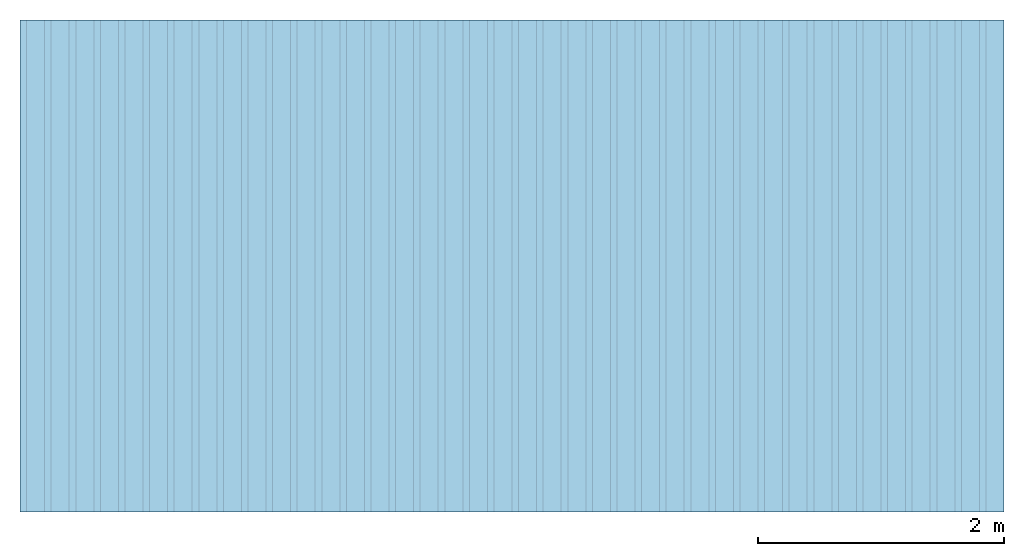
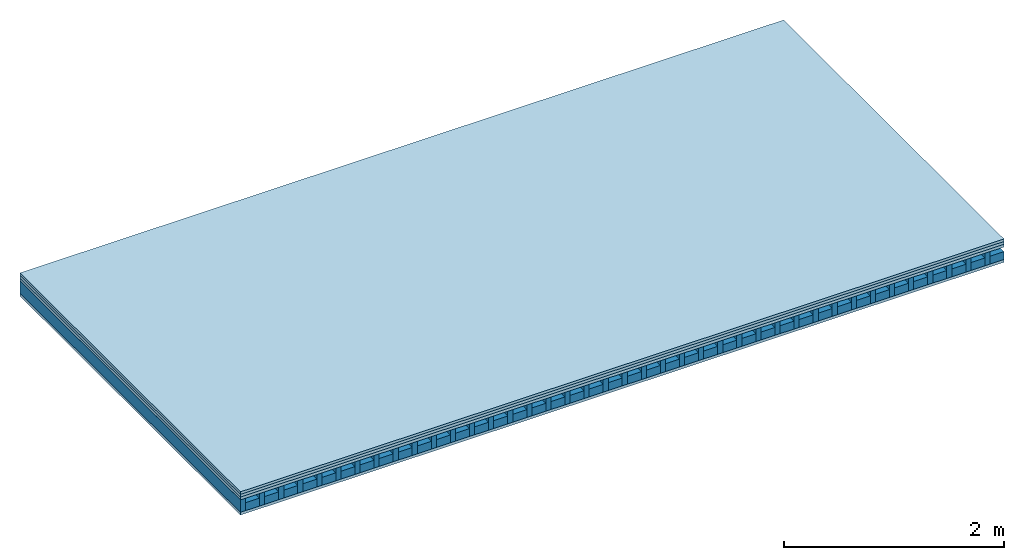
# One storey: 4 plates, 2 members, 1 element without a shape of its own.
"""IFC4 building model written with IfcOpenShell, lengths in metres."""

import ifcopenshell
import ifcopenshell.guid

model = None  # the IFC model being written
_history = None  # IfcOwnerHistory: only IFC2X3 demands one
_inside = {}  # id of a spatial element -> (the spatial element, [elements in it])
_under = {}  # id of a project, library or spatial element -> (it, [spatial elements below it])
_declared = {}  # id of a project -> (the project, [libraries it declares])
_typed = {}  # id of a type object -> (the type object, [elements of that type])
_made_of = {}  # id of a material, layer set ... -> (it, [elements and type objects made of it])


def new_model(schema):
    """Start an empty IFC model of exactly this schema.

    Asked for "IFC4X3", IfcOpenShell would pick the latest addendum, in which some entities
    have other attributes; the version numbers below select the first issue.
    IFC2X3 requires an IfcOwnerHistory on every rooted entity: one is made here for all.
    """
    global model, _history
    if schema == "IFC4X3":
        model = ifcopenshell.file(schema_version=(4, 3, 0, 0))
    else:
        model = ifcopenshell.file(schema=schema)
    _inside.clear()
    _under.clear()
    _declared.clear()
    _typed.clear()
    _made_of.clear()
    _history = None
    if model.schema == "IFC2X3":
        org = make("IfcOrganization", Name="unknown")
        user = make(
            "IfcPersonAndOrganization",
            ThePerson=make("IfcPerson", FamilyName="unknown"),
            TheOrganization=org,
        )
        app = make(
            "IfcApplication",
            ApplicationDeveloper=org,
            Version="unknown",
            ApplicationFullName="unknown",
            ApplicationIdentifier="unknown",
        )
        _history = make(
            "IfcOwnerHistory",
            OwningUser=user,
            OwningApplication=app,
            ChangeAction="ADDED",
            CreationDate=0,
        )
    return model


def make(cls, **values):
    """One entity of the class cls with the attributes given. An attribute that is None is left unset."""
    return model.create_entity(
        cls, **{name: value for name, value in values.items() if value is not None}
    )


def rooted(cls, **values):
    """An entity with a GlobalId (a new one), such as an element, a storey or a relation."""
    return make(cls, GlobalId=ifcopenshell.guid.new(), OwnerHistory=_history, **values)


def si_unit(unit_type, name, prefix=None):
    """IfcSIUnit, for example si_unit("LENGTHUNIT", "METRE", prefix="MILLI")."""
    return make("IfcSIUnit", UnitType=unit_type, Prefix=prefix, Name=name)


def derived_unit(unit_type, elements):
    """IfcDerivedUnit: a product of units, each with its exponent."""
    return make(
        "IfcDerivedUnit",
        Elements=[
            make("IfcDerivedUnitElement", Unit=unit, Exponent=power)
            for unit, power in elements
        ],
        UnitType=unit_type,
    )


def assignment(units):
    """IfcUnitAssignment: the units of a project."""
    return None if units is None else make("IfcUnitAssignment", Units=units)


def point(xyz):
    """IfcCartesianPoint."""
    return None if xyz is None else make("IfcCartesianPoint", Coordinates=xyz)


def direction(xyz):
    """IfcDirection."""
    return None if xyz is None else make("IfcDirection", DirectionRatios=xyz)


def frame(location, z_axis=None, x_axis=None):
    """IfcAxis2Placement3D, a coordinate frame: its origin and axes. An axis left out is left unset."""
    return make(
        "IfcAxis2Placement3D",
        Location=point(location),
        Axis=direction(z_axis),
        RefDirection=direction(x_axis),
    )


def frame_2d(location, x_axis=None):
    """IfcAxis2Placement2D, a coordinate frame in the plane: its origin and x axis."""
    return make(
        "IfcAxis2Placement2D", Location=point(location), RefDirection=direction(x_axis)
    )


def origin():
    """The frame at (0, 0, 0) with its axes left unset."""
    return frame((0.0, 0.0, 0.0))


def origin_with_axes():
    """The frame at (0, 0, 0) with the z axis (0, 0, 1) and the x axis (1, 0, 0) written out."""
    return frame((0.0, 0.0, 0.0), z_axis=(0.0, 0.0, 1.0), x_axis=(1.0, 0.0, 0.0))


def place(relative_to, where):
    """IfcLocalPlacement: puts the frame where relative to a parent placement (None: the world)."""
    return make(
        "IfcLocalPlacement", PlacementRelTo=relative_to, RelativePlacement=where
    )


def context(
    kind, dimensions, precision=None, world=None, true_north=None, identifier=None
):
    """IfcGeometricRepresentationContext, for example the 3D "Model" context."""
    return make(
        "IfcGeometricRepresentationContext",
        ContextIdentifier=identifier,
        ContextType=kind,
        CoordinateSpaceDimension=dimensions,
        Precision=precision,
        WorldCoordinateSystem=world,
        TrueNorth=true_north,
    )


def project(units=None, contexts=None):
    """IfcProject with its units and contexts."""
    return rooted(
        "IfcProject",
        Name="project",
        RepresentationContexts=contexts,
        UnitsInContext=assignment(units),
    )


def spatial(cls, under=None, at=None, **own):
    """A site, building, storey or space (cls), placed at a placement, below another one or the project."""
    s = rooted(cls, ObjectPlacement=at, **own)
    if under is not None:
        _under.setdefault(under.id(), (under, []))[1].append(s)
    return s


def profile(cls, at=None, kind="AREA", **sizes):
    """A parametric profile (cls). Its sizes go by their IFC names, for example OverallWidth=200.0."""
    return make(cls, ProfileType=kind, Position=at, **sizes)


def rectangle(**sizes):
    """IfcRectangleProfileDef."""
    return profile("IfcRectangleProfileDef", **sizes)


def extrude(swept, where, along, depth):
    """IfcExtrudedAreaSolid: the profile swept, set in the frame where, extruded along a direction by depth."""
    return make(
        "IfcExtrudedAreaSolid",
        SweptArea=swept,
        Position=where,
        ExtrudedDirection=direction(along),
        Depth=depth,
    )


def shape(context_of_items, identifier, shape_type, items):
    """IfcShapeRepresentation: the items that make up one representation, for example the "Body"."""
    return make(
        "IfcShapeRepresentation",
        ContextOfItems=context_of_items,
        RepresentationIdentifier=identifier,
        RepresentationType=shape_type,
        Items=items,
    )


def material(Name=None, Category=None):
    """IfcMaterial."""
    return make("IfcMaterial", Name=Name, Category=Category)


def layer(
    of_material, thickness, ventilated=None, Name=None, Category=None, Priority=None
):
    """IfcMaterialLayer: one layer of a wall or slab, of a material (None: an air gap)."""
    return make(
        "IfcMaterialLayer",
        Material=of_material,
        LayerThickness=thickness,
        IsVentilated=ventilated,
        Name=Name,
        Category=Category,
        Priority=Priority,
    )


def layer_set(layers, Name=None):
    """IfcMaterialLayerSet."""
    return make("IfcMaterialLayerSet", MaterialLayers=layers, LayerSetName=Name)


def made_of(thing, what):
    """Note that an element or type object is made of a material, layer set ...; save() writes the relation."""
    if what is not None:
        _made_of.setdefault(what.id(), (what, []))[1].append(thing)
    return thing


def type_object(cls, material=None, **own):
    """A type object (cls), such as IfcWallType, which elements share."""
    return made_of(rooted(cls, **own), material)


def element(
    cls,
    number,
    at=None,
    inside=None,
    cuts=None,
    type_object=None,
    material=None,
    context=None,
    identifier="Body",
    shape_type=None,
    held_by="IfcProductDefinitionShape",
    body=None,
    shapes=None,
    **own,
):
    """One element of the class cls, such as IfcWall. Its Tag is "e" and its number.

    at: its placement. inside: the storey or other place that contains it. cuts: it is an
    opening in that element (IfcRelVoidsElement). A single representation is given by context,
    identifier, shape_type and body (its items); several are given by shapes. held_by: the class
    of the entity that holds the representations. save() writes the other relations.
    """
    e = rooted(cls, Tag="e%d" % number, ObjectPlacement=at, **own)
    if body is not None:
        shapes = [shape(context, identifier, shape_type, body)]
    if shapes is not None:
        e.Representation = make(held_by, Representations=shapes)
    if inside is not None:
        _inside.setdefault(inside.id(), (inside, []))[1].append(e)
    if cuts is not None:
        rooted(
            "IfcRelVoidsElement", RelatingBuildingElement=cuts, RelatedOpeningElement=e
        )
    if type_object is not None:
        _typed.setdefault(type_object.id(), (type_object, []))[1].append(e)
    return made_of(e, material)


def aggregate(whole, parts):
    """IfcRelAggregates: a whole, such as a stair, and the parts it consists of."""
    return rooted("IfcRelAggregates", RelatingObject=whole, RelatedObjects=parts)


def save(model, path):
    """Write the relations noted so far, then the file.

    IfcRelAggregates (storeys below a building ...), IfcRelContainedInSpatialStructure (elements
    in a storey), IfcRelDefinesByType, IfcRelAssociatesMaterial and IfcRelDeclares: one each for
    every whole, place, type object, material and project.
    """
    for whole, parts in _under.values():
        aggregate(whole, parts)
    for where, things in _inside.values():
        rooted(
            "IfcRelContainedInSpatialStructure",
            RelatedElements=things,
            RelatingStructure=where,
        )
    for kind, things in _typed.values():
        rooted("IfcRelDefinesByType", RelatedObjects=things, RelatingType=kind)
    for what, things in _made_of.values():
        rooted("IfcRelAssociatesMaterial", RelatedObjects=things, RelatingMaterial=what)
    for by, libraries in _declared.values():
        rooted("IfcRelDeclares", RelatingContext=by, RelatedDefinitions=libraries)
    model.write(path)


model = new_model("IFC4")

# Units and contexts
plan_context = context("Plan", 3, precision=1e-05, world=origin(), true_north=direction((0.0, 1.0)))
model_context = context("Model", 3, precision=1e-05, world=origin(), true_north=direction((0.0, 1.0)))
ifc_project = project(units=[si_unit("LENGTHUNIT", "METRE"), derived_unit("SOUNDPRESSUREUNIT", [(si_unit("PRESSUREUNIT", "PASCAL", prefix="MICRO"), 0)]), si_unit("ENERGYUNIT", "JOULE", prefix="MEGA"), si_unit("MASSUNIT", "GRAM", prefix="KILO"), derived_unit("THERMALTRANSMITTANCEUNIT", [(si_unit("POWERUNIT", "WATT"), 1), (si_unit("AREAUNIT", "SQUARE_METRE"), -1), (si_unit("THERMODYNAMICTEMPERATUREUNIT", "KELVIN"), -1)]), derived_unit("AREADENSITYUNIT", [(si_unit("MASSUNIT", "GRAM", prefix="KILO"), 1), (si_unit("AREAUNIT", "SQUARE_METRE"), -1)]), derived_unit("USERDEFINED", [(si_unit("ENERGYUNIT", "JOULE", prefix="MEGA"), 1), (si_unit("AREAUNIT", "SQUARE_METRE"), -1)])], contexts=[plan_context, model_context])

# Site, building, storey
site = spatial("IfcSite", under=ifc_project)
building_placement = place(None, origin())
building = spatial("IfcBuilding", under=site, at=building_placement)
storey_placement = place(building_placement, origin())
storey = spatial("IfcBuildingStorey", under=building, at=storey_placement)

# Slab, members, plates
ifc_material_1 = material(Name="Chipboard", Category="07.015")
ifc_layer_1 = layer(ifc_material_1, 0.028, Name="On-material")
ifc_material_2 = material(Name="EP2, 30mm")
ifc_layer_2 = layer(ifc_material_2, 0.03, Name="Impact sound insulation")
ifc_material_3 = material(Name="box-element sheathing above")
ifc_layer_3 = layer(ifc_material_3, 0.031, Name="Sub-floor")
ifc_layer_4 = layer(None, 0.138, Name="Supporting structure")
ifc_material_4 = material(Name="box-element sheathing below")
ifc_layer_5 = layer(ifc_material_4, 0.031, Name="Lower layer 1")
ifc_layer_set = layer_set([ifc_layer_1, ifc_layer_2, ifc_layer_3, ifc_layer_4, ifc_layer_5])
slab_type = type_object("IfcSlabType", Name="A0028", PredefinedType="NOTDEFINED", material=ifc_layer_set)
slab_placement = place(None, frame((0.0, 0.0, 0.0), z_axis=(0.0, 0.0, -1.0), x_axis=(1.0, 0.0, 0.0)))
slab = element("IfcSlab", 1, at=slab_placement, inside=storey, type_object=slab_type, material=ifc_layer_set, Name="Slab #1")
ifc_material_5 = material(Name="box-element LKE")
member_1_placement = place(slab_placement, origin())
member_1 = element("IfcMember", 2, at=member_1_placement, material=ifc_material_5, Name="Supporting structure", context=plan_context, shape_type="SweptSolid", body=[
    extrude(rectangle(XDim=0.054, YDim=0.138, at=frame_2d((0.027, 0.069), x_axis=(1.0, 0.0))), frame((0.0, 4.0, 0.089), z_axis=(0.0, -1.0, 0.0), x_axis=(1.0, 0.0, 0.0)), (0.0, 0.0, 1.0), 4.0),
    extrude(rectangle(XDim=0.054, YDim=0.138, at=frame_2d((0.027, 0.069), x_axis=(1.0, 0.0))), frame((0.2, 4.0, 0.089), z_axis=(0.0, -1.0, 0.0), x_axis=(1.0, 0.0, 0.0)), (0.0, 0.0, 1.0), 4.0),
    extrude(rectangle(XDim=0.054, YDim=0.138, at=frame_2d((0.027, 0.069), x_axis=(1.0, 0.0))), frame((0.4, 4.0, 0.089), z_axis=(0.0, -1.0, 0.0), x_axis=(1.0, 0.0, 0.0)), (0.0, 0.0, 1.0), 4.0),
    extrude(rectangle(XDim=0.054, YDim=0.138, at=frame_2d((0.027, 0.069), x_axis=(1.0, 0.0))), frame((0.6, 4.0, 0.089), z_axis=(0.0, -1.0, 0.0), x_axis=(1.0, 0.0, 0.0)), (0.0, 0.0, 1.0), 4.0),
    extrude(rectangle(XDim=0.054, YDim=0.138, at=frame_2d((0.027, 0.069), x_axis=(1.0, 0.0))), frame((0.8, 4.0, 0.089), z_axis=(0.0, -1.0, 0.0), x_axis=(1.0, 0.0, 0.0)), (0.0, 0.0, 1.0), 4.0),
    extrude(rectangle(XDim=0.054, YDim=0.138, at=frame_2d((0.027, 0.069), x_axis=(1.0, 0.0))), frame((1.0, 4.0, 0.089), z_axis=(0.0, -1.0, 0.0), x_axis=(1.0, 0.0, 0.0)), (0.0, 0.0, 1.0), 4.0),
    extrude(rectangle(XDim=0.054, YDim=0.138, at=frame_2d((0.027, 0.069), x_axis=(1.0, 0.0))), frame((1.2, 4.0, 0.089), z_axis=(0.0, -1.0, 0.0), x_axis=(1.0, 0.0, 0.0)), (0.0, 0.0, 1.0), 4.0),
    extrude(rectangle(XDim=0.054, YDim=0.138, at=frame_2d((0.027, 0.069), x_axis=(1.0, 0.0))), frame((1.4, 4.0, 0.089), z_axis=(0.0, -1.0, 0.0), x_axis=(1.0, 0.0, 0.0)), (0.0, 0.0, 1.0), 4.0),
    extrude(rectangle(XDim=0.054, YDim=0.138, at=frame_2d((0.027, 0.069), x_axis=(1.0, 0.0))), frame((1.6, 4.0, 0.089), z_axis=(0.0, -1.0, 0.0), x_axis=(1.0, 0.0, 0.0)), (0.0, 0.0, 1.0), 4.0),
    extrude(rectangle(XDim=0.054, YDim=0.138, at=frame_2d((0.027, 0.069), x_axis=(1.0, 0.0))), frame((1.8, 4.0, 0.089), z_axis=(0.0, -1.0, 0.0), x_axis=(1.0, 0.0, 0.0)), (0.0, 0.0, 1.0), 4.0),
    extrude(rectangle(XDim=0.054, YDim=0.138, at=frame_2d((0.027, 0.069), x_axis=(1.0, 0.0))), frame((2.0, 4.0, 0.089), z_axis=(0.0, -1.0, 0.0), x_axis=(1.0, 0.0, 0.0)), (0.0, 0.0, 1.0), 4.0),
    extrude(rectangle(XDim=0.054, YDim=0.138, at=frame_2d((0.027, 0.069), x_axis=(1.0, 0.0))), frame((2.2, 4.0, 0.089), z_axis=(0.0, -1.0, 0.0), x_axis=(1.0, 0.0, 0.0)), (0.0, 0.0, 1.0), 4.0),
    extrude(rectangle(XDim=0.054, YDim=0.138, at=frame_2d((0.027, 0.069), x_axis=(1.0, 0.0))), frame((2.4, 4.0, 0.089), z_axis=(0.0, -1.0, 0.0), x_axis=(1.0, 0.0, 0.0)), (0.0, 0.0, 1.0), 4.0),
    extrude(rectangle(XDim=0.054, YDim=0.138, at=frame_2d((0.027, 0.069), x_axis=(1.0, 0.0))), frame((2.6, 4.0, 0.089), z_axis=(0.0, -1.0, 0.0), x_axis=(1.0, 0.0, 0.0)), (0.0, 0.0, 1.0), 4.0),
    extrude(rectangle(XDim=0.054, YDim=0.138, at=frame_2d((0.027, 0.069), x_axis=(1.0, 0.0))), frame((2.8, 4.0, 0.089), z_axis=(0.0, -1.0, 0.0), x_axis=(1.0, 0.0, 0.0)), (0.0, 0.0, 1.0), 4.0),
    extrude(rectangle(XDim=0.054, YDim=0.138, at=frame_2d((0.027, 0.069), x_axis=(1.0, 0.0))), frame((3.0, 4.0, 0.089), z_axis=(0.0, -1.0, 0.0), x_axis=(1.0, 0.0, 0.0)), (0.0, 0.0, 1.0), 4.0),
    extrude(rectangle(XDim=0.054, YDim=0.138, at=frame_2d((0.027, 0.069), x_axis=(1.0, 0.0))), frame((3.2, 4.0, 0.089), z_axis=(0.0, -1.0, 0.0), x_axis=(1.0, 0.0, 0.0)), (0.0, 0.0, 1.0), 4.0),
    extrude(rectangle(XDim=0.054, YDim=0.138, at=frame_2d((0.027, 0.069), x_axis=(1.0, 0.0))), frame((3.4, 4.0, 0.089), z_axis=(0.0, -1.0, 0.0), x_axis=(1.0, 0.0, 0.0)), (0.0, 0.0, 1.0), 4.0),
    extrude(rectangle(XDim=0.054, YDim=0.138, at=frame_2d((0.027, 0.069), x_axis=(1.0, 0.0))), frame((3.6, 4.0, 0.089), z_axis=(0.0, -1.0, 0.0), x_axis=(1.0, 0.0, 0.0)), (0.0, 0.0, 1.0), 4.0),
    extrude(rectangle(XDim=0.054, YDim=0.138, at=frame_2d((0.027, 0.069), x_axis=(1.0, 0.0))), frame((3.8, 4.0, 0.089), z_axis=(0.0, -1.0, 0.0), x_axis=(1.0, 0.0, 0.0)), (0.0, 0.0, 1.0), 4.0),
    extrude(rectangle(XDim=0.054, YDim=0.138, at=frame_2d((0.027, 0.069), x_axis=(1.0, 0.0))), frame((4.0, 4.0, 0.089), z_axis=(0.0, -1.0, 0.0), x_axis=(1.0, 0.0, 0.0)), (0.0, 0.0, 1.0), 4.0),
    extrude(rectangle(XDim=0.054, YDim=0.138, at=frame_2d((0.027, 0.069), x_axis=(1.0, 0.0))), frame((4.2, 4.0, 0.089), z_axis=(0.0, -1.0, 0.0), x_axis=(1.0, 0.0, 0.0)), (0.0, 0.0, 1.0), 4.0),
    extrude(rectangle(XDim=0.054, YDim=0.138, at=frame_2d((0.027, 0.069), x_axis=(1.0, 0.0))), frame((4.4, 4.0, 0.089), z_axis=(0.0, -1.0, 0.0), x_axis=(1.0, 0.0, 0.0)), (0.0, 0.0, 1.0), 4.0),
    extrude(rectangle(XDim=0.054, YDim=0.138, at=frame_2d((0.027, 0.069), x_axis=(1.0, 0.0))), frame((4.6, 4.0, 0.089), z_axis=(0.0, -1.0, 0.0), x_axis=(1.0, 0.0, 0.0)), (0.0, 0.0, 1.0), 4.0),
    extrude(rectangle(XDim=0.054, YDim=0.138, at=frame_2d((0.027, 0.069), x_axis=(1.0, 0.0))), frame((4.8, 4.0, 0.089), z_axis=(0.0, -1.0, 0.0), x_axis=(1.0, 0.0, 0.0)), (0.0, 0.0, 1.0), 4.0),
    extrude(rectangle(XDim=0.054, YDim=0.138, at=frame_2d((0.027, 0.069), x_axis=(1.0, 0.0))), frame((5.0, 4.0, 0.089), z_axis=(0.0, -1.0, 0.0), x_axis=(1.0, 0.0, 0.0)), (0.0, 0.0, 1.0), 4.0),
    extrude(rectangle(XDim=0.054, YDim=0.138, at=frame_2d((0.027, 0.069), x_axis=(1.0, 0.0))), frame((5.2, 4.0, 0.089), z_axis=(0.0, -1.0, 0.0), x_axis=(1.0, 0.0, 0.0)), (0.0, 0.0, 1.0), 4.0),
    extrude(rectangle(XDim=0.054, YDim=0.138, at=frame_2d((0.027, 0.069), x_axis=(1.0, 0.0))), frame((5.4, 4.0, 0.089), z_axis=(0.0, -1.0, 0.0), x_axis=(1.0, 0.0, 0.0)), (0.0, 0.0, 1.0), 4.0),
    extrude(rectangle(XDim=0.054, YDim=0.138, at=frame_2d((0.027, 0.069), x_axis=(1.0, 0.0))), frame((5.6, 4.0, 0.089), z_axis=(0.0, -1.0, 0.0), x_axis=(1.0, 0.0, 0.0)), (0.0, 0.0, 1.0), 4.0),
    extrude(rectangle(XDim=0.054, YDim=0.138, at=frame_2d((0.027, 0.069), x_axis=(1.0, 0.0))), frame((5.8, 4.0, 0.089), z_axis=(0.0, -1.0, 0.0), x_axis=(1.0, 0.0, 0.0)), (0.0, 0.0, 1.0), 4.0),
    extrude(rectangle(XDim=0.054, YDim=0.138, at=frame_2d((0.027, 0.069), x_axis=(1.0, 0.0))), frame((6.0, 4.0, 0.089), z_axis=(0.0, -1.0, 0.0), x_axis=(1.0, 0.0, 0.0)), (0.0, 0.0, 1.0), 4.0),
    extrude(rectangle(XDim=0.054, YDim=0.138, at=frame_2d((0.027, 0.069), x_axis=(1.0, 0.0))), frame((6.2, 4.0, 0.089), z_axis=(0.0, -1.0, 0.0), x_axis=(1.0, 0.0, 0.0)), (0.0, 0.0, 1.0), 4.0),
    extrude(rectangle(XDim=0.054, YDim=0.138, at=frame_2d((0.027, 0.069), x_axis=(1.0, 0.0))), frame((6.4, 4.0, 0.089), z_axis=(0.0, -1.0, 0.0), x_axis=(1.0, 0.0, 0.0)), (0.0, 0.0, 1.0), 4.0),
    extrude(rectangle(XDim=0.054, YDim=0.138, at=frame_2d((0.027, 0.069), x_axis=(1.0, 0.0))), frame((6.6, 4.0, 0.089), z_axis=(0.0, -1.0, 0.0), x_axis=(1.0, 0.0, 0.0)), (0.0, 0.0, 1.0), 4.0),
    extrude(rectangle(XDim=0.054, YDim=0.138, at=frame_2d((0.027, 0.069), x_axis=(1.0, 0.0))), frame((6.8, 4.0, 0.089), z_axis=(0.0, -1.0, 0.0), x_axis=(1.0, 0.0, 0.0)), (0.0, 0.0, 1.0), 4.0),
    extrude(rectangle(XDim=0.054, YDim=0.138, at=frame_2d((0.027, 0.069), x_axis=(1.0, 0.0))), frame((7.0, 4.0, 0.089), z_axis=(0.0, -1.0, 0.0), x_axis=(1.0, 0.0, 0.0)), (0.0, 0.0, 1.0), 4.0),
    extrude(rectangle(XDim=0.054, YDim=0.138, at=frame_2d((0.027, 0.069), x_axis=(1.0, 0.0))), frame((7.2, 4.0, 0.089), z_axis=(0.0, -1.0, 0.0), x_axis=(1.0, 0.0, 0.0)), (0.0, 0.0, 1.0), 4.0),
    extrude(rectangle(XDim=0.054, YDim=0.138, at=frame_2d((0.027, 0.069), x_axis=(1.0, 0.0))), frame((7.4, 4.0, 0.089), z_axis=(0.0, -1.0, 0.0), x_axis=(1.0, 0.0, 0.0)), (0.0, 0.0, 1.0), 4.0),
    extrude(rectangle(XDim=0.054, YDim=0.138, at=frame_2d((0.027, 0.069), x_axis=(1.0, 0.0))), frame((7.6, 4.0, 0.089), z_axis=(0.0, -1.0, 0.0), x_axis=(1.0, 0.0, 0.0)), (0.0, 0.0, 1.0), 4.0),
    extrude(rectangle(XDim=0.054, YDim=0.138, at=frame_2d((0.027, 0.069), x_axis=(1.0, 0.0))), frame((7.8, 4.0, 0.089), z_axis=(0.0, -1.0, 0.0), x_axis=(1.0, 0.0, 0.0)), (0.0, 0.0, 1.0), 4.0),
])
ifc_material_6 = material()
member_2_placement = place(slab_placement, origin())
member_2 = element("IfcMember", 3, at=member_2_placement, material=ifc_material_6, Name="in supporting structure", context=plan_context, shape_type="SweptSolid", body=[
    extrude(rectangle(XDim=0.146, YDim=0.087, at=frame_2d((0.073, 0.0435), x_axis=(1.0, 0.0))), frame((0.054, 4.0, 0.14), z_axis=(0.0, -1.0, 0.0), x_axis=(1.0, 0.0, 0.0)), (0.0, 0.0, 1.0), 4.0),
    extrude(rectangle(XDim=0.146, YDim=0.087, at=frame_2d((0.073, 0.0435), x_axis=(1.0, 0.0))), frame((0.254, 4.0, 0.14), z_axis=(0.0, -1.0, 0.0), x_axis=(1.0, 0.0, 0.0)), (0.0, 0.0, 1.0), 4.0),
    extrude(rectangle(XDim=0.146, YDim=0.087, at=frame_2d((0.073, 0.0435), x_axis=(1.0, 0.0))), frame((0.454, 4.0, 0.14), z_axis=(0.0, -1.0, 0.0), x_axis=(1.0, 0.0, 0.0)), (0.0, 0.0, 1.0), 4.0),
    extrude(rectangle(XDim=0.146, YDim=0.087, at=frame_2d((0.073, 0.0435), x_axis=(1.0, 0.0))), frame((0.654, 4.0, 0.14), z_axis=(0.0, -1.0, 0.0), x_axis=(1.0, 0.0, 0.0)), (0.0, 0.0, 1.0), 4.0),
    extrude(rectangle(XDim=0.146, YDim=0.087, at=frame_2d((0.073, 0.0435), x_axis=(1.0, 0.0))), frame((0.854, 4.0, 0.14), z_axis=(0.0, -1.0, 0.0), x_axis=(1.0, 0.0, 0.0)), (0.0, 0.0, 1.0), 4.0),
    extrude(rectangle(XDim=0.146, YDim=0.087, at=frame_2d((0.073, 0.0435), x_axis=(1.0, 0.0))), frame((1.054, 4.0, 0.14), z_axis=(0.0, -1.0, 0.0), x_axis=(1.0, 0.0, 0.0)), (0.0, 0.0, 1.0), 4.0),
    extrude(rectangle(XDim=0.146, YDim=0.087, at=frame_2d((0.073, 0.0435), x_axis=(1.0, 0.0))), frame((1.254, 4.0, 0.14), z_axis=(0.0, -1.0, 0.0), x_axis=(1.0, 0.0, 0.0)), (0.0, 0.0, 1.0), 4.0),
    extrude(rectangle(XDim=0.146, YDim=0.087, at=frame_2d((0.073, 0.0435), x_axis=(1.0, 0.0))), frame((1.454, 4.0, 0.14), z_axis=(0.0, -1.0, 0.0), x_axis=(1.0, 0.0, 0.0)), (0.0, 0.0, 1.0), 4.0),
    extrude(rectangle(XDim=0.146, YDim=0.087, at=frame_2d((0.073, 0.0435), x_axis=(1.0, 0.0))), frame((1.654, 4.0, 0.14), z_axis=(0.0, -1.0, 0.0), x_axis=(1.0, 0.0, 0.0)), (0.0, 0.0, 1.0), 4.0),
    extrude(rectangle(XDim=0.146, YDim=0.087, at=frame_2d((0.073, 0.0435), x_axis=(1.0, 0.0))), frame((1.854, 4.0, 0.14), z_axis=(0.0, -1.0, 0.0), x_axis=(1.0, 0.0, 0.0)), (0.0, 0.0, 1.0), 4.0),
    extrude(rectangle(XDim=0.146, YDim=0.087, at=frame_2d((0.073, 0.0435), x_axis=(1.0, 0.0))), frame((2.054, 4.0, 0.14), z_axis=(0.0, -1.0, 0.0), x_axis=(1.0, 0.0, 0.0)), (0.0, 0.0, 1.0), 4.0),
    extrude(rectangle(XDim=0.146, YDim=0.087, at=frame_2d((0.073, 0.0435), x_axis=(1.0, 0.0))), frame((2.254, 4.0, 0.14), z_axis=(0.0, -1.0, 0.0), x_axis=(1.0, 0.0, 0.0)), (0.0, 0.0, 1.0), 4.0),
    extrude(rectangle(XDim=0.146, YDim=0.087, at=frame_2d((0.073, 0.0435), x_axis=(1.0, 0.0))), frame((2.454, 4.0, 0.14), z_axis=(0.0, -1.0, 0.0), x_axis=(1.0, 0.0, 0.0)), (0.0, 0.0, 1.0), 4.0),
    extrude(rectangle(XDim=0.146, YDim=0.087, at=frame_2d((0.073, 0.0435), x_axis=(1.0, 0.0))), frame((2.654, 4.0, 0.14), z_axis=(0.0, -1.0, 0.0), x_axis=(1.0, 0.0, 0.0)), (0.0, 0.0, 1.0), 4.0),
    extrude(rectangle(XDim=0.146, YDim=0.087, at=frame_2d((0.073, 0.0435), x_axis=(1.0, 0.0))), frame((2.854, 4.0, 0.14), z_axis=(0.0, -1.0, 0.0), x_axis=(1.0, 0.0, 0.0)), (0.0, 0.0, 1.0), 4.0),
    extrude(rectangle(XDim=0.146, YDim=0.087, at=frame_2d((0.073, 0.0435), x_axis=(1.0, 0.0))), frame((3.054, 4.0, 0.14), z_axis=(0.0, -1.0, 0.0), x_axis=(1.0, 0.0, 0.0)), (0.0, 0.0, 1.0), 4.0),
    extrude(rectangle(XDim=0.146, YDim=0.087, at=frame_2d((0.073, 0.0435), x_axis=(1.0, 0.0))), frame((3.254, 4.0, 0.14), z_axis=(0.0, -1.0, 0.0), x_axis=(1.0, 0.0, 0.0)), (0.0, 0.0, 1.0), 4.0),
    extrude(rectangle(XDim=0.146, YDim=0.087, at=frame_2d((0.073, 0.0435), x_axis=(1.0, 0.0))), frame((3.454, 4.0, 0.14), z_axis=(0.0, -1.0, 0.0), x_axis=(1.0, 0.0, 0.0)), (0.0, 0.0, 1.0), 4.0),
    extrude(rectangle(XDim=0.146, YDim=0.087, at=frame_2d((0.073, 0.0435), x_axis=(1.0, 0.0))), frame((3.654, 4.0, 0.14), z_axis=(0.0, -1.0, 0.0), x_axis=(1.0, 0.0, 0.0)), (0.0, 0.0, 1.0), 4.0),
    extrude(rectangle(XDim=0.146, YDim=0.087, at=frame_2d((0.073, 0.0435), x_axis=(1.0, 0.0))), frame((3.854, 4.0, 0.14), z_axis=(0.0, -1.0, 0.0), x_axis=(1.0, 0.0, 0.0)), (0.0, 0.0, 1.0), 4.0),
    extrude(rectangle(XDim=0.146, YDim=0.087, at=frame_2d((0.073, 0.0435), x_axis=(1.0, 0.0))), frame((4.054, 4.0, 0.14), z_axis=(0.0, -1.0, 0.0), x_axis=(1.0, 0.0, 0.0)), (0.0, 0.0, 1.0), 4.0),
    extrude(rectangle(XDim=0.146, YDim=0.087, at=frame_2d((0.073, 0.0435), x_axis=(1.0, 0.0))), frame((4.254, 4.0, 0.14), z_axis=(0.0, -1.0, 0.0), x_axis=(1.0, 0.0, 0.0)), (0.0, 0.0, 1.0), 4.0),
    extrude(rectangle(XDim=0.146, YDim=0.087, at=frame_2d((0.073, 0.0435), x_axis=(1.0, 0.0))), frame((4.454, 4.0, 0.14), z_axis=(0.0, -1.0, 0.0), x_axis=(1.0, 0.0, 0.0)), (0.0, 0.0, 1.0), 4.0),
    extrude(rectangle(XDim=0.146, YDim=0.087, at=frame_2d((0.073, 0.0435), x_axis=(1.0, 0.0))), frame((4.654, 4.0, 0.14), z_axis=(0.0, -1.0, 0.0), x_axis=(1.0, 0.0, 0.0)), (0.0, 0.0, 1.0), 4.0),
    extrude(rectangle(XDim=0.146, YDim=0.087, at=frame_2d((0.073, 0.0435), x_axis=(1.0, 0.0))), frame((4.854, 4.0, 0.14), z_axis=(0.0, -1.0, 0.0), x_axis=(1.0, 0.0, 0.0)), (0.0, 0.0, 1.0), 4.0),
    extrude(rectangle(XDim=0.146, YDim=0.087, at=frame_2d((0.073, 0.0435), x_axis=(1.0, 0.0))), frame((5.054, 4.0, 0.14), z_axis=(0.0, -1.0, 0.0), x_axis=(1.0, 0.0, 0.0)), (0.0, 0.0, 1.0), 4.0),
    extrude(rectangle(XDim=0.146, YDim=0.087, at=frame_2d((0.073, 0.0435), x_axis=(1.0, 0.0))), frame((5.254, 4.0, 0.14), z_axis=(0.0, -1.0, 0.0), x_axis=(1.0, 0.0, 0.0)), (0.0, 0.0, 1.0), 4.0),
    extrude(rectangle(XDim=0.146, YDim=0.087, at=frame_2d((0.073, 0.0435), x_axis=(1.0, 0.0))), frame((5.454, 4.0, 0.14), z_axis=(0.0, -1.0, 0.0), x_axis=(1.0, 0.0, 0.0)), (0.0, 0.0, 1.0), 4.0),
    extrude(rectangle(XDim=0.146, YDim=0.087, at=frame_2d((0.073, 0.0435), x_axis=(1.0, 0.0))), frame((5.654, 4.0, 0.14), z_axis=(0.0, -1.0, 0.0), x_axis=(1.0, 0.0, 0.0)), (0.0, 0.0, 1.0), 4.0),
    extrude(rectangle(XDim=0.146, YDim=0.087, at=frame_2d((0.073, 0.0435), x_axis=(1.0, 0.0))), frame((5.854, 4.0, 0.14), z_axis=(0.0, -1.0, 0.0), x_axis=(1.0, 0.0, 0.0)), (0.0, 0.0, 1.0), 4.0),
    extrude(rectangle(XDim=0.146, YDim=0.087, at=frame_2d((0.073, 0.0435), x_axis=(1.0, 0.0))), frame((6.054, 4.0, 0.14), z_axis=(0.0, -1.0, 0.0), x_axis=(1.0, 0.0, 0.0)), (0.0, 0.0, 1.0), 4.0),
    extrude(rectangle(XDim=0.146, YDim=0.087, at=frame_2d((0.073, 0.0435), x_axis=(1.0, 0.0))), frame((6.254, 4.0, 0.14), z_axis=(0.0, -1.0, 0.0), x_axis=(1.0, 0.0, 0.0)), (0.0, 0.0, 1.0), 4.0),
    extrude(rectangle(XDim=0.146, YDim=0.087, at=frame_2d((0.073, 0.0435), x_axis=(1.0, 0.0))), frame((6.454, 4.0, 0.14), z_axis=(0.0, -1.0, 0.0), x_axis=(1.0, 0.0, 0.0)), (0.0, 0.0, 1.0), 4.0),
    extrude(rectangle(XDim=0.146, YDim=0.087, at=frame_2d((0.073, 0.0435), x_axis=(1.0, 0.0))), frame((6.654, 4.0, 0.14), z_axis=(0.0, -1.0, 0.0), x_axis=(1.0, 0.0, 0.0)), (0.0, 0.0, 1.0), 4.0),
    extrude(rectangle(XDim=0.146, YDim=0.087, at=frame_2d((0.073, 0.0435), x_axis=(1.0, 0.0))), frame((6.854, 4.0, 0.14), z_axis=(0.0, -1.0, 0.0), x_axis=(1.0, 0.0, 0.0)), (0.0, 0.0, 1.0), 4.0),
    extrude(rectangle(XDim=0.146, YDim=0.087, at=frame_2d((0.073, 0.0435), x_axis=(1.0, 0.0))), frame((7.054, 4.0, 0.14), z_axis=(0.0, -1.0, 0.0), x_axis=(1.0, 0.0, 0.0)), (0.0, 0.0, 1.0), 4.0),
    extrude(rectangle(XDim=0.146, YDim=0.087, at=frame_2d((0.073, 0.0435), x_axis=(1.0, 0.0))), frame((7.254, 4.0, 0.14), z_axis=(0.0, -1.0, 0.0), x_axis=(1.0, 0.0, 0.0)), (0.0, 0.0, 1.0), 4.0),
    extrude(rectangle(XDim=0.146, YDim=0.087, at=frame_2d((0.073, 0.0435), x_axis=(1.0, 0.0))), frame((7.454, 4.0, 0.14), z_axis=(0.0, -1.0, 0.0), x_axis=(1.0, 0.0, 0.0)), (0.0, 0.0, 1.0), 4.0),
    extrude(rectangle(XDim=0.146, YDim=0.087, at=frame_2d((0.073, 0.0435), x_axis=(1.0, 0.0))), frame((7.654, 4.0, 0.14), z_axis=(0.0, -1.0, 0.0), x_axis=(1.0, 0.0, 0.0)), (0.0, 0.0, 1.0), 4.0),
    extrude(rectangle(XDim=0.146, YDim=0.087, at=frame_2d((0.073, 0.0435), x_axis=(1.0, 0.0))), frame((7.854, 4.0, 0.14), z_axis=(0.0, -1.0, 0.0), x_axis=(1.0, 0.0, 0.0)), (0.0, 0.0, 1.0), 4.0),
])
plate_1_placement = place(slab_placement, origin())
plate_1 = element("IfcPlate", 4, at=plate_1_placement, material=ifc_material_1, Name="On-material", context=plan_context, shape_type="SweptSolid", body=[
    extrude(rectangle(XDim=8.0, YDim=4.0, at=frame_2d((4.0, 2.0), x_axis=(1.0, 0.0))), origin_with_axes(), (0.0, 0.0, 1.0), 0.028),
])
plate_2_placement = place(slab_placement, origin())
plate_2 = element("IfcPlate", 5, at=plate_2_placement, material=ifc_material_2, Name="Impact sound insulation", context=plan_context, shape_type="SweptSolid", body=[
    extrude(rectangle(XDim=8.0, YDim=4.0, at=frame_2d((4.0, 2.0), x_axis=(1.0, 0.0))), frame((0.0, 0.0, 0.028), z_axis=(0.0, 0.0, 1.0), x_axis=(1.0, 0.0, 0.0)), (0.0, 0.0, 1.0), 0.03),
])
plate_3_placement = place(slab_placement, origin())
plate_3 = element("IfcPlate", 6, at=plate_3_placement, material=ifc_material_3, Name="Sub-floor", context=plan_context, shape_type="SweptSolid", body=[
    extrude(rectangle(XDim=8.0, YDim=4.0, at=frame_2d((4.0, 2.0), x_axis=(1.0, 0.0))), frame((0.0, 0.0, 0.058), z_axis=(0.0, 0.0, 1.0), x_axis=(1.0, 0.0, 0.0)), (0.0, 0.0, 1.0), 0.031),
])
plate_4_placement = place(slab_placement, origin())
plate_4 = element("IfcPlate", 7, at=plate_4_placement, material=ifc_material_4, Name="Lower layer 1", context=plan_context, shape_type="SweptSolid", body=[
    extrude(rectangle(XDim=8.0, YDim=4.0, at=frame_2d((4.0, 2.0), x_axis=(1.0, 0.0))), frame((0.0, 0.0, 0.227), z_axis=(0.0, 0.0, 1.0), x_axis=(1.0, 0.0, 0.0)), (0.0, 0.0, 1.0), 0.031),
])
aggregate(slab, [plate_1, plate_2, plate_3, member_1, member_2, plate_4])

save(model, "model.ifc")
